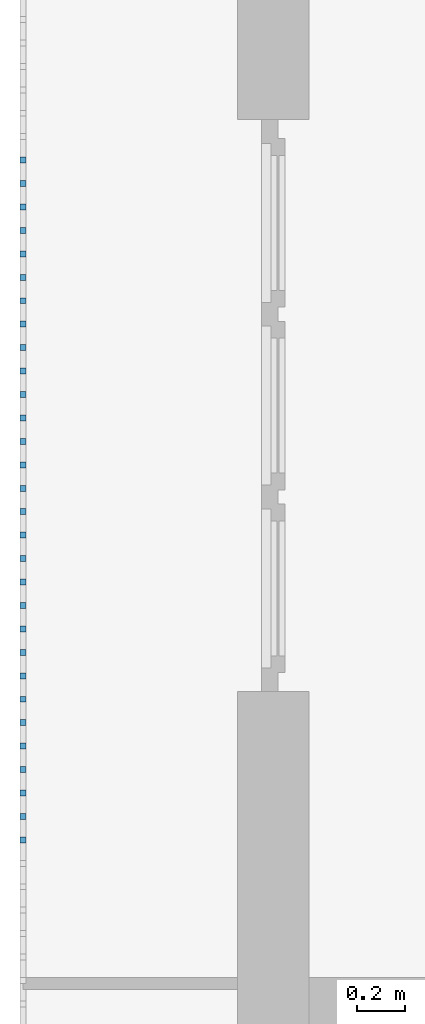
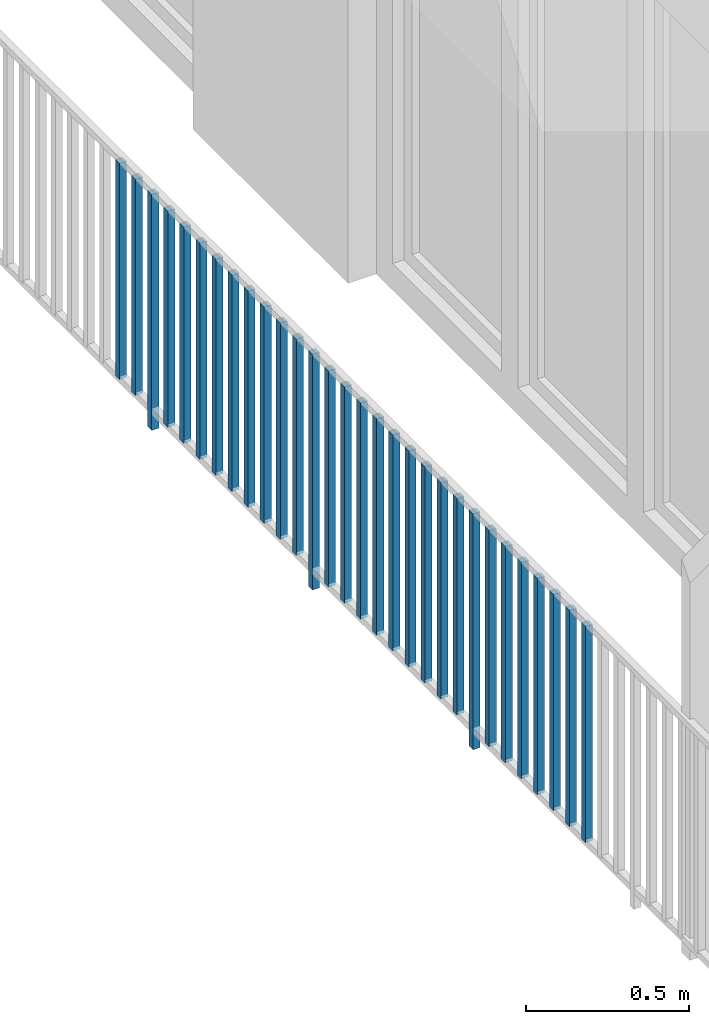
# One storey, part 32 of 48: 30 building element parts, 1 element without a shape of its own.
"""IFC4 building model written with IfcOpenShell, lengths in metres."""

from ifc_helpers import new_model, entity, si_unit, converted_unit, derived_unit, direction, frame, origin_with_axes, place, context, subcontext, project, spatial, polygons, material, type_object, element, aggregate, save


model = new_model("IFC4")

# Units and contexts
model_context = context("Model", 3, precision=1e-05, world=origin_with_axes(), true_north=direction((0.0, 1.0)))
body_context = subcontext(model_context, "Body", "Model", "MODEL_VIEW")
ifc_project = project(units=[si_unit("LENGTHUNIT", "METRE"), si_unit("AREAUNIT", "SQUARE_METRE"), si_unit("VOLUMEUNIT", "CUBIC_METRE"), converted_unit("PLANEANGLEUNIT", "DEGREE", entity("IfcPlaneAngleMeasure", 0.0174532925199), si_unit("PLANEANGLEUNIT", "RADIAN"), dimensions=[0, 0, 0, 0, 0, 0, 0]), converted_unit("TIMEUNIT", "Year", entity("IfcTimeMeasure", 31556926.0), si_unit("TIMEUNIT", "SECOND"), dimensions=[0, 0, 1, 0, 0, 0, 0]), si_unit("MASSUNIT", "GRAM", prefix="KILO"), si_unit("THERMODYNAMICTEMPERATUREUNIT", "DEGREE_CELSIUS"), si_unit("LUMINOUSINTENSITYUNIT", "LUMEN"), si_unit("ENERGYUNIT", "JOULE", prefix="MEGA"), derived_unit("THERMALCONDUCTANCEUNIT", [(si_unit("POWERUNIT", "WATT"), 1), (si_unit("LENGTHUNIT", "METRE"), -1), (si_unit("THERMODYNAMICTEMPERATUREUNIT", "KELVIN"), -1)]), derived_unit("SPECIFICHEATCAPACITYUNIT", [(si_unit("ENERGYUNIT", "JOULE"), 1), (si_unit("MASSUNIT", "GRAM", prefix="KILO"), -1), (si_unit("THERMODYNAMICTEMPERATUREUNIT", "KELVIN"), -1)]), derived_unit("MASSDENSITYUNIT", [(si_unit("MASSUNIT", "GRAM", prefix="KILO"), 1), (si_unit("VOLUMEUNIT", "CUBIC_METRE"), -1)])], contexts=[model_context])

# Site, building, storey
site_placement = place(None, origin_with_axes())
site = spatial("IfcSite", under=ifc_project, at=site_placement, CompositionType="ELEMENT")
building_placement = place(site_placement, origin_with_axes())
building = spatial("IfcBuilding", under=site, at=building_placement, CompositionType="ELEMENT")
storey_placement = place(building_placement, frame((0.0, 0.0, 3.4), z_axis=(0.0, 0.0, 1.0), x_axis=(1.0, 0.0, 0.0)))
storey = spatial("IfcBuildingStorey", under=building, at=storey_placement, Name="1. Geschoss", CompositionType="ELEMENT", Elevation=3.4)

# Railing, building element parts
railing_type = type_object("IfcRailingType", PredefinedType="NOTDEFINED")
railing_placement = place(storey_placement, frame((10.2378006196, 9.82118776896, 0.0), z_axis=(0.0, 0.0, 1.0), x_axis=(1.0, 0.0, 0.0)))
railing = element("IfcRailing", 1, at=railing_placement, inside=storey, type_object=railing_type, PredefinedType="NOTDEFINED")
ifc_material = material()
building_element_part_1_placement = place(railing_placement, origin_with_axes())
building_element_part_1 = element("IfcBuildingElementPart", 2, at=building_element_part_1_placement, material=ifc_material, PredefinedType="NOTDEFINED", context=body_context, shape_type="Tessellation", body=[
    polygons([(-22.8925, -4.7325, 0.07), (-22.8675, -4.7325, 0.07), (-22.8675, -4.7325, 0.8775), (-22.8925, -4.7325, 0.8775), (-22.8925, -4.7075, 0.07), (-22.8675, -4.7075, 0.07), (-22.8675, -4.7075, 0.8775), (-22.8925, -4.7075, 0.8775)], [[[1, 2, 3, 4]], [[1, 5, 6, 2]], [[2, 6, 7, 3]], [[4, 3, 7, 8]], [[5, 1, 4, 8]], [[6, 5, 8, 7]]], closed=True),
])
building_element_part_2_placement = place(railing_placement, origin_with_axes())
building_element_part_2 = element("IfcBuildingElementPart", 3, at=building_element_part_2_placement, material=ifc_material, PredefinedType="NOTDEFINED", context=body_context, shape_type="Tessellation", body=[
    polygons([(-22.8925, -4.83083333333, 0.07), (-22.8675, -4.83083333333, 0.07), (-22.8675, -4.83083333333, 0.8775), (-22.8925, -4.83083333333, 0.8775), (-22.8925, -4.80583333333, 0.07), (-22.8675, -4.80583333333, 0.07), (-22.8675, -4.80583333333, 0.8775), (-22.8925, -4.80583333333, 0.8775)], [[[1, 2, 3, 4]], [[1, 5, 6, 2]], [[2, 6, 7, 3]], [[4, 3, 7, 8]], [[5, 1, 4, 8]], [[6, 5, 8, 7]]], closed=True),
])
building_element_part_3_placement = place(railing_placement, origin_with_axes())
building_element_part_3 = element("IfcBuildingElementPart", 4, at=building_element_part_3_placement, material=ifc_material, PredefinedType="NOTDEFINED", context=body_context, shape_type="Tessellation", body=[
    polygons([(-22.8925, -4.92916666667, 0.0), (-22.8675, -4.92916666667, 0.0), (-22.8675, -4.92916666667, 0.88), (-22.8925, -4.92916666667, 0.88), (-22.8925, -4.90416666667, 0.0), (-22.8675, -4.90416666667, 0.0), (-22.8675, -4.90416666667, 0.88), (-22.8925, -4.90416666667, 0.88)], [[[1, 2, 3, 4]], [[1, 5, 6, 2]], [[2, 6, 7, 3]], [[4, 3, 7, 8]], [[5, 1, 4, 8]], [[6, 5, 8, 7]]], closed=True),
])
building_element_part_4_placement = place(railing_placement, origin_with_axes())
building_element_part_4 = element("IfcBuildingElementPart", 5, at=building_element_part_4_placement, material=ifc_material, PredefinedType="NOTDEFINED", context=body_context, shape_type="Tessellation", body=[
    polygons([(-22.8925, -5.0275, 0.07), (-22.8675, -5.0275, 0.07), (-22.8675, -5.0275, 0.8775), (-22.8925, -5.0275, 0.8775), (-22.8925, -5.0025, 0.07), (-22.8675, -5.0025, 0.07), (-22.8675, -5.0025, 0.8775), (-22.8925, -5.0025, 0.8775)], [[[1, 2, 3, 4]], [[1, 5, 6, 2]], [[2, 6, 7, 3]], [[4, 3, 7, 8]], [[5, 1, 4, 8]], [[6, 5, 8, 7]]], closed=True),
])
building_element_part_5_placement = place(railing_placement, origin_with_axes())
building_element_part_5 = element("IfcBuildingElementPart", 6, at=building_element_part_5_placement, material=ifc_material, PredefinedType="NOTDEFINED", context=body_context, shape_type="Tessellation", body=[
    polygons([(-22.8925, -5.12583333333, 0.07), (-22.8675, -5.12583333333, 0.07), (-22.8675, -5.12583333333, 0.8775), (-22.8925, -5.12583333333, 0.8775), (-22.8925, -5.10083333333, 0.07), (-22.8675, -5.10083333333, 0.07), (-22.8675, -5.10083333333, 0.8775), (-22.8925, -5.10083333333, 0.8775)], [[[1, 2, 3, 4]], [[1, 5, 6, 2]], [[2, 6, 7, 3]], [[4, 3, 7, 8]], [[5, 1, 4, 8]], [[6, 5, 8, 7]]], closed=True),
])
building_element_part_6_placement = place(railing_placement, origin_with_axes())
building_element_part_6 = element("IfcBuildingElementPart", 7, at=building_element_part_6_placement, material=ifc_material, PredefinedType="NOTDEFINED", context=body_context, shape_type="Tessellation", body=[
    polygons([(-22.8925, -5.22416666667, 0.07), (-22.8675, -5.22416666667, 0.07), (-22.8675, -5.22416666667, 0.8775), (-22.8925, -5.22416666667, 0.8775), (-22.8925, -5.19916666667, 0.07), (-22.8675, -5.19916666667, 0.07), (-22.8675, -5.19916666667, 0.8775), (-22.8925, -5.19916666667, 0.8775)], [[[1, 2, 3, 4]], [[1, 5, 6, 2]], [[2, 6, 7, 3]], [[4, 3, 7, 8]], [[5, 1, 4, 8]], [[6, 5, 8, 7]]], closed=True),
])
building_element_part_7_placement = place(railing_placement, origin_with_axes())
building_element_part_7 = element("IfcBuildingElementPart", 8, at=building_element_part_7_placement, material=ifc_material, PredefinedType="NOTDEFINED", context=body_context, shape_type="Tessellation", body=[
    polygons([(-22.8925, -5.3225, 0.07), (-22.8675, -5.3225, 0.07), (-22.8675, -5.3225, 0.8775), (-22.8925, -5.3225, 0.8775), (-22.8925, -5.2975, 0.07), (-22.8675, -5.2975, 0.07), (-22.8675, -5.2975, 0.8775), (-22.8925, -5.2975, 0.8775)], [[[1, 2, 3, 4]], [[1, 5, 6, 2]], [[2, 6, 7, 3]], [[4, 3, 7, 8]], [[5, 1, 4, 8]], [[6, 5, 8, 7]]], closed=True),
])
building_element_part_8_placement = place(railing_placement, origin_with_axes())
building_element_part_8 = element("IfcBuildingElementPart", 9, at=building_element_part_8_placement, material=ifc_material, PredefinedType="NOTDEFINED", context=body_context, shape_type="Tessellation", body=[
    polygons([(-22.8925, -5.42083333333, 0.07), (-22.8675, -5.42083333333, 0.07), (-22.8675, -5.42083333333, 0.8775), (-22.8925, -5.42083333333, 0.8775), (-22.8925, -5.39583333333, 0.07), (-22.8675, -5.39583333333, 0.07), (-22.8675, -5.39583333333, 0.8775), (-22.8925, -5.39583333333, 0.8775)], [[[1, 2, 3, 4]], [[1, 5, 6, 2]], [[2, 6, 7, 3]], [[4, 3, 7, 8]], [[5, 1, 4, 8]], [[6, 5, 8, 7]]], closed=True),
])
building_element_part_9_placement = place(railing_placement, origin_with_axes())
building_element_part_9 = element("IfcBuildingElementPart", 10, at=building_element_part_9_placement, material=ifc_material, PredefinedType="NOTDEFINED", context=body_context, shape_type="Tessellation", body=[
    polygons([(-22.8925, -5.51916666667, 0.07), (-22.8675, -5.51916666667, 0.07), (-22.8675, -5.51916666667, 0.8775), (-22.8925, -5.51916666667, 0.8775), (-22.8925, -5.49416666667, 0.07), (-22.8675, -5.49416666667, 0.07), (-22.8675, -5.49416666667, 0.8775), (-22.8925, -5.49416666667, 0.8775)], [[[1, 2, 3, 4]], [[1, 5, 6, 2]], [[2, 6, 7, 3]], [[4, 3, 7, 8]], [[5, 1, 4, 8]], [[6, 5, 8, 7]]], closed=True),
])
building_element_part_10_placement = place(railing_placement, origin_with_axes())
building_element_part_10 = element("IfcBuildingElementPart", 11, at=building_element_part_10_placement, material=ifc_material, PredefinedType="NOTDEFINED", context=body_context, shape_type="Tessellation", body=[
    polygons([(-22.8925, -5.6175, 0.07), (-22.8675, -5.6175, 0.07), (-22.8675, -5.6175, 0.8775), (-22.8925, -5.6175, 0.8775), (-22.8925, -5.5925, 0.07), (-22.8675, -5.5925, 0.07), (-22.8675, -5.5925, 0.8775), (-22.8925, -5.5925, 0.8775)], [[[1, 2, 3, 4]], [[1, 5, 6, 2]], [[2, 6, 7, 3]], [[4, 3, 7, 8]], [[5, 1, 4, 8]], [[6, 5, 8, 7]]], closed=True),
])
building_element_part_11_placement = place(railing_placement, origin_with_axes())
building_element_part_11 = element("IfcBuildingElementPart", 12, at=building_element_part_11_placement, material=ifc_material, PredefinedType="NOTDEFINED", context=body_context, shape_type="Tessellation", body=[
    polygons([(-22.8925, -5.71583333333, 0.07), (-22.8675, -5.71583333333, 0.07), (-22.8675, -5.71583333333, 0.8775), (-22.8925, -5.71583333333, 0.8775), (-22.8925, -5.69083333333, 0.07), (-22.8675, -5.69083333333, 0.07), (-22.8675, -5.69083333333, 0.8775), (-22.8925, -5.69083333333, 0.8775)], [[[1, 2, 3, 4]], [[1, 5, 6, 2]], [[2, 6, 7, 3]], [[4, 3, 7, 8]], [[5, 1, 4, 8]], [[6, 5, 8, 7]]], closed=True),
])
building_element_part_12_placement = place(railing_placement, origin_with_axes())
building_element_part_12 = element("IfcBuildingElementPart", 13, at=building_element_part_12_placement, material=ifc_material, PredefinedType="NOTDEFINED", context=body_context, shape_type="Tessellation", body=[
    polygons([(-22.8925, -5.81416666667, 0.07), (-22.8675, -5.81416666667, 0.07), (-22.8675, -5.81416666667, 0.8775), (-22.8925, -5.81416666667, 0.8775), (-22.8925, -5.78916666667, 0.07), (-22.8675, -5.78916666667, 0.07), (-22.8675, -5.78916666667, 0.8775), (-22.8925, -5.78916666667, 0.8775)], [[[1, 2, 3, 4]], [[1, 5, 6, 2]], [[2, 6, 7, 3]], [[4, 3, 7, 8]], [[5, 1, 4, 8]], [[6, 5, 8, 7]]], closed=True),
])
building_element_part_13_placement = place(railing_placement, origin_with_axes())
building_element_part_13 = element("IfcBuildingElementPart", 14, at=building_element_part_13_placement, material=ifc_material, PredefinedType="NOTDEFINED", context=body_context, shape_type="Tessellation", body=[
    polygons([(-22.8925, -5.9125, 0.0), (-22.8675, -5.9125, 0.0), (-22.8675, -5.9125, 0.88), (-22.8925, -5.9125, 0.88), (-22.8925, -5.8875, 0.0), (-22.8675, -5.8875, 0.0), (-22.8675, -5.8875, 0.88), (-22.8925, -5.8875, 0.88)], [[[1, 2, 3, 4]], [[1, 5, 6, 2]], [[2, 6, 7, 3]], [[4, 3, 7, 8]], [[5, 1, 4, 8]], [[6, 5, 8, 7]]], closed=True),
])
building_element_part_14_placement = place(railing_placement, origin_with_axes())
building_element_part_14 = element("IfcBuildingElementPart", 15, at=building_element_part_14_placement, material=ifc_material, PredefinedType="NOTDEFINED", context=body_context, shape_type="Tessellation", body=[
    polygons([(-22.8925, -6.01083333333, 0.07), (-22.8675, -6.01083333333, 0.07), (-22.8675, -6.01083333333, 0.8775), (-22.8925, -6.01083333333, 0.8775), (-22.8925, -5.98583333333, 0.07), (-22.8675, -5.98583333333, 0.07), (-22.8675, -5.98583333333, 0.8775), (-22.8925, -5.98583333333, 0.8775)], [[[1, 2, 3, 4]], [[1, 5, 6, 2]], [[2, 6, 7, 3]], [[4, 3, 7, 8]], [[5, 1, 4, 8]], [[6, 5, 8, 7]]], closed=True),
])
building_element_part_15_placement = place(railing_placement, origin_with_axes())
building_element_part_15 = element("IfcBuildingElementPart", 16, at=building_element_part_15_placement, material=ifc_material, PredefinedType="NOTDEFINED", context=body_context, shape_type="Tessellation", body=[
    polygons([(-22.8925, -6.10916666667, 0.07), (-22.8675, -6.10916666667, 0.07), (-22.8675, -6.10916666667, 0.8775), (-22.8925, -6.10916666667, 0.8775), (-22.8925, -6.08416666667, 0.07), (-22.8675, -6.08416666667, 0.07), (-22.8675, -6.08416666667, 0.8775), (-22.8925, -6.08416666667, 0.8775)], [[[1, 2, 3, 4]], [[1, 5, 6, 2]], [[2, 6, 7, 3]], [[4, 3, 7, 8]], [[5, 1, 4, 8]], [[6, 5, 8, 7]]], closed=True),
])
building_element_part_16_placement = place(railing_placement, origin_with_axes())
building_element_part_16 = element("IfcBuildingElementPart", 17, at=building_element_part_16_placement, material=ifc_material, PredefinedType="NOTDEFINED", context=body_context, shape_type="Tessellation", body=[
    polygons([(-22.8925, -6.2075, 0.07), (-22.8675, -6.2075, 0.07), (-22.8675, -6.2075, 0.8775), (-22.8925, -6.2075, 0.8775), (-22.8925, -6.1825, 0.07), (-22.8675, -6.1825, 0.07), (-22.8675, -6.1825, 0.8775), (-22.8925, -6.1825, 0.8775)], [[[1, 2, 3, 4]], [[1, 5, 6, 2]], [[2, 6, 7, 3]], [[4, 3, 7, 8]], [[5, 1, 4, 8]], [[6, 5, 8, 7]]], closed=True),
])
building_element_part_17_placement = place(railing_placement, origin_with_axes())
building_element_part_17 = element("IfcBuildingElementPart", 18, at=building_element_part_17_placement, material=ifc_material, PredefinedType="NOTDEFINED", context=body_context, shape_type="Tessellation", body=[
    polygons([(-22.8925, -6.30583333333, 0.07), (-22.8675, -6.30583333333, 0.07), (-22.8675, -6.30583333333, 0.8775), (-22.8925, -6.30583333333, 0.8775), (-22.8925, -6.28083333333, 0.07), (-22.8675, -6.28083333333, 0.07), (-22.8675, -6.28083333333, 0.8775), (-22.8925, -6.28083333333, 0.8775)], [[[1, 2, 3, 4]], [[1, 5, 6, 2]], [[2, 6, 7, 3]], [[4, 3, 7, 8]], [[5, 1, 4, 8]], [[6, 5, 8, 7]]], closed=True),
])
building_element_part_18_placement = place(railing_placement, origin_with_axes())
building_element_part_18 = element("IfcBuildingElementPart", 19, at=building_element_part_18_placement, material=ifc_material, PredefinedType="NOTDEFINED", context=body_context, shape_type="Tessellation", body=[
    polygons([(-22.8925, -6.40416666667, 0.07), (-22.8675, -6.40416666667, 0.07), (-22.8675, -6.40416666667, 0.8775), (-22.8925, -6.40416666667, 0.8775), (-22.8925, -6.37916666667, 0.07), (-22.8675, -6.37916666667, 0.07), (-22.8675, -6.37916666667, 0.8775), (-22.8925, -6.37916666667, 0.8775)], [[[1, 2, 3, 4]], [[1, 5, 6, 2]], [[2, 6, 7, 3]], [[4, 3, 7, 8]], [[5, 1, 4, 8]], [[6, 5, 8, 7]]], closed=True),
])
building_element_part_19_placement = place(railing_placement, origin_with_axes())
building_element_part_19 = element("IfcBuildingElementPart", 20, at=building_element_part_19_placement, material=ifc_material, PredefinedType="NOTDEFINED", context=body_context, shape_type="Tessellation", body=[
    polygons([(-22.8925, -6.5025, 0.07), (-22.8675, -6.5025, 0.07), (-22.8675, -6.5025, 0.8775), (-22.8925, -6.5025, 0.8775), (-22.8925, -6.4775, 0.07), (-22.8675, -6.4775, 0.07), (-22.8675, -6.4775, 0.8775), (-22.8925, -6.4775, 0.8775)], [[[1, 2, 3, 4]], [[1, 5, 6, 2]], [[2, 6, 7, 3]], [[4, 3, 7, 8]], [[5, 1, 4, 8]], [[6, 5, 8, 7]]], closed=True),
])
building_element_part_20_placement = place(railing_placement, origin_with_axes())
building_element_part_20 = element("IfcBuildingElementPart", 21, at=building_element_part_20_placement, material=ifc_material, PredefinedType="NOTDEFINED", context=body_context, shape_type="Tessellation", body=[
    polygons([(-22.8925, -6.60083333333, 0.07), (-22.8675, -6.60083333333, 0.07), (-22.8675, -6.60083333333, 0.8775), (-22.8925, -6.60083333333, 0.8775), (-22.8925, -6.57583333333, 0.07), (-22.8675, -6.57583333333, 0.07), (-22.8675, -6.57583333333, 0.8775), (-22.8925, -6.57583333333, 0.8775)], [[[1, 2, 3, 4]], [[1, 5, 6, 2]], [[2, 6, 7, 3]], [[4, 3, 7, 8]], [[5, 1, 4, 8]], [[6, 5, 8, 7]]], closed=True),
])
building_element_part_21_placement = place(railing_placement, origin_with_axes())
building_element_part_21 = element("IfcBuildingElementPart", 22, at=building_element_part_21_placement, material=ifc_material, PredefinedType="NOTDEFINED", context=body_context, shape_type="Tessellation", body=[
    polygons([(-22.8925, -6.69916666667, 0.07), (-22.8675, -6.69916666667, 0.07), (-22.8675, -6.69916666667, 0.8775), (-22.8925, -6.69916666667, 0.8775), (-22.8925, -6.67416666667, 0.07), (-22.8675, -6.67416666667, 0.07), (-22.8675, -6.67416666667, 0.8775), (-22.8925, -6.67416666667, 0.8775)], [[[1, 2, 3, 4]], [[1, 5, 6, 2]], [[2, 6, 7, 3]], [[4, 3, 7, 8]], [[5, 1, 4, 8]], [[6, 5, 8, 7]]], closed=True),
])
building_element_part_22_placement = place(railing_placement, origin_with_axes())
building_element_part_22 = element("IfcBuildingElementPart", 23, at=building_element_part_22_placement, material=ifc_material, PredefinedType="NOTDEFINED", context=body_context, shape_type="Tessellation", body=[
    polygons([(-22.8925, -6.7975, 0.07), (-22.8675, -6.7975, 0.07), (-22.8675, -6.7975, 0.8775), (-22.8925, -6.7975, 0.8775), (-22.8925, -6.7725, 0.07), (-22.8675, -6.7725, 0.07), (-22.8675, -6.7725, 0.8775), (-22.8925, -6.7725, 0.8775)], [[[1, 2, 3, 4]], [[1, 5, 6, 2]], [[2, 6, 7, 3]], [[4, 3, 7, 8]], [[5, 1, 4, 8]], [[6, 5, 8, 7]]], closed=True),
])
building_element_part_23_placement = place(railing_placement, origin_with_axes())
building_element_part_23 = element("IfcBuildingElementPart", 24, at=building_element_part_23_placement, material=ifc_material, PredefinedType="NOTDEFINED", context=body_context, shape_type="Tessellation", body=[
    polygons([(-22.8925, -6.89583333333, 0.0), (-22.8675, -6.89583333333, 0.0), (-22.8675, -6.89583333333, 0.88), (-22.8925, -6.89583333333, 0.88), (-22.8925, -6.87083333333, 0.0), (-22.8675, -6.87083333333, 0.0), (-22.8675, -6.87083333333, 0.88), (-22.8925, -6.87083333333, 0.88)], [[[1, 2, 3, 4]], [[1, 5, 6, 2]], [[2, 6, 7, 3]], [[4, 3, 7, 8]], [[5, 1, 4, 8]], [[6, 5, 8, 7]]], closed=True),
])
building_element_part_24_placement = place(railing_placement, origin_with_axes())
building_element_part_24 = element("IfcBuildingElementPart", 25, at=building_element_part_24_placement, material=ifc_material, PredefinedType="NOTDEFINED", context=body_context, shape_type="Tessellation", body=[
    polygons([(-22.8925, -6.99416666667, 0.07), (-22.8675, -6.99416666667, 0.07), (-22.8675, -6.99416666667, 0.8775), (-22.8925, -6.99416666667, 0.8775), (-22.8925, -6.96916666667, 0.07), (-22.8675, -6.96916666667, 0.07), (-22.8675, -6.96916666667, 0.8775), (-22.8925, -6.96916666667, 0.8775)], [[[1, 2, 3, 4]], [[1, 5, 6, 2]], [[2, 6, 7, 3]], [[4, 3, 7, 8]], [[5, 1, 4, 8]], [[6, 5, 8, 7]]], closed=True),
])
building_element_part_25_placement = place(railing_placement, origin_with_axes())
building_element_part_25 = element("IfcBuildingElementPart", 26, at=building_element_part_25_placement, material=ifc_material, PredefinedType="NOTDEFINED", context=body_context, shape_type="Tessellation", body=[
    polygons([(-22.8925, -7.0925, 0.07), (-22.8675, -7.0925, 0.07), (-22.8675, -7.0925, 0.8775), (-22.8925, -7.0925, 0.8775), (-22.8925, -7.0675, 0.07), (-22.8675, -7.0675, 0.07), (-22.8675, -7.0675, 0.8775), (-22.8925, -7.0675, 0.8775)], [[[1, 2, 3, 4]], [[1, 5, 6, 2]], [[2, 6, 7, 3]], [[4, 3, 7, 8]], [[5, 1, 4, 8]], [[6, 5, 8, 7]]], closed=True),
])
building_element_part_26_placement = place(railing_placement, origin_with_axes())
building_element_part_26 = element("IfcBuildingElementPart", 27, at=building_element_part_26_placement, material=ifc_material, PredefinedType="NOTDEFINED", context=body_context, shape_type="Tessellation", body=[
    polygons([(-22.8925, -7.19083333333, 0.07), (-22.8675, -7.19083333333, 0.07), (-22.8675, -7.19083333333, 0.8775), (-22.8925, -7.19083333333, 0.8775), (-22.8925, -7.16583333333, 0.07), (-22.8675, -7.16583333333, 0.07), (-22.8675, -7.16583333333, 0.8775), (-22.8925, -7.16583333333, 0.8775)], [[[1, 2, 3, 4]], [[1, 5, 6, 2]], [[2, 6, 7, 3]], [[4, 3, 7, 8]], [[5, 1, 4, 8]], [[6, 5, 8, 7]]], closed=True),
])
building_element_part_27_placement = place(railing_placement, origin_with_axes())
building_element_part_27 = element("IfcBuildingElementPart", 28, at=building_element_part_27_placement, material=ifc_material, PredefinedType="NOTDEFINED", context=body_context, shape_type="Tessellation", body=[
    polygons([(-22.8925, -7.28916666667, 0.07), (-22.8675, -7.28916666667, 0.07), (-22.8675, -7.28916666667, 0.8775), (-22.8925, -7.28916666667, 0.8775), (-22.8925, -7.26416666667, 0.07), (-22.8675, -7.26416666667, 0.07), (-22.8675, -7.26416666667, 0.8775), (-22.8925, -7.26416666667, 0.8775)], [[[1, 2, 3, 4]], [[1, 5, 6, 2]], [[2, 6, 7, 3]], [[4, 3, 7, 8]], [[5, 1, 4, 8]], [[6, 5, 8, 7]]], closed=True),
])
building_element_part_28_placement = place(railing_placement, origin_with_axes())
building_element_part_28 = element("IfcBuildingElementPart", 29, at=building_element_part_28_placement, material=ifc_material, PredefinedType="NOTDEFINED", context=body_context, shape_type="Tessellation", body=[
    polygons([(-22.8925, -7.3875, 0.07), (-22.8675, -7.3875, 0.07), (-22.8675, -7.3875, 0.8775), (-22.8925, -7.3875, 0.8775), (-22.8925, -7.3625, 0.07), (-22.8675, -7.3625, 0.07), (-22.8675, -7.3625, 0.8775), (-22.8925, -7.3625, 0.8775)], [[[1, 2, 3, 4]], [[1, 5, 6, 2]], [[2, 6, 7, 3]], [[4, 3, 7, 8]], [[5, 1, 4, 8]], [[6, 5, 8, 7]]], closed=True),
])
building_element_part_29_placement = place(railing_placement, origin_with_axes())
building_element_part_29 = element("IfcBuildingElementPart", 30, at=building_element_part_29_placement, material=ifc_material, PredefinedType="NOTDEFINED", context=body_context, shape_type="Tessellation", body=[
    polygons([(-22.8925, -7.48583333333, 0.07), (-22.8675, -7.48583333333, 0.07), (-22.8675, -7.48583333333, 0.8775), (-22.8925, -7.48583333333, 0.8775), (-22.8925, -7.46083333333, 0.07), (-22.8675, -7.46083333333, 0.07), (-22.8675, -7.46083333333, 0.8775), (-22.8925, -7.46083333333, 0.8775)], [[[1, 2, 3, 4]], [[1, 5, 6, 2]], [[2, 6, 7, 3]], [[4, 3, 7, 8]], [[5, 1, 4, 8]], [[6, 5, 8, 7]]], closed=True),
])
building_element_part_30_placement = place(railing_placement, origin_with_axes())
building_element_part_30 = element("IfcBuildingElementPart", 31, at=building_element_part_30_placement, material=ifc_material, PredefinedType="NOTDEFINED", context=body_context, shape_type="Tessellation", body=[
    polygons([(-22.8925, -7.58416666667, 0.07), (-22.8675, -7.58416666667, 0.07), (-22.8675, -7.58416666667, 0.8775), (-22.8925, -7.58416666667, 0.8775), (-22.8925, -7.55916666667, 0.07), (-22.8675, -7.55916666667, 0.07), (-22.8675, -7.55916666667, 0.8775), (-22.8925, -7.55916666667, 0.8775)], [[[1, 2, 3, 4]], [[1, 5, 6, 2]], [[2, 6, 7, 3]], [[4, 3, 7, 8]], [[5, 1, 4, 8]], [[6, 5, 8, 7]]], closed=True),
])
aggregate(railing, [building_element_part_1, building_element_part_2, building_element_part_3, building_element_part_4, building_element_part_5, building_element_part_6, building_element_part_7, building_element_part_8, building_element_part_9, building_element_part_10, building_element_part_11, building_element_part_12, building_element_part_13, building_element_part_14, building_element_part_15, building_element_part_16, building_element_part_17, building_element_part_18, building_element_part_19, building_element_part_20, building_element_part_21, building_element_part_22, building_element_part_23, building_element_part_24, building_element_part_25, building_element_part_26, building_element_part_27, building_element_part_28, building_element_part_29, building_element_part_30])

save(model, "model.ifc")
